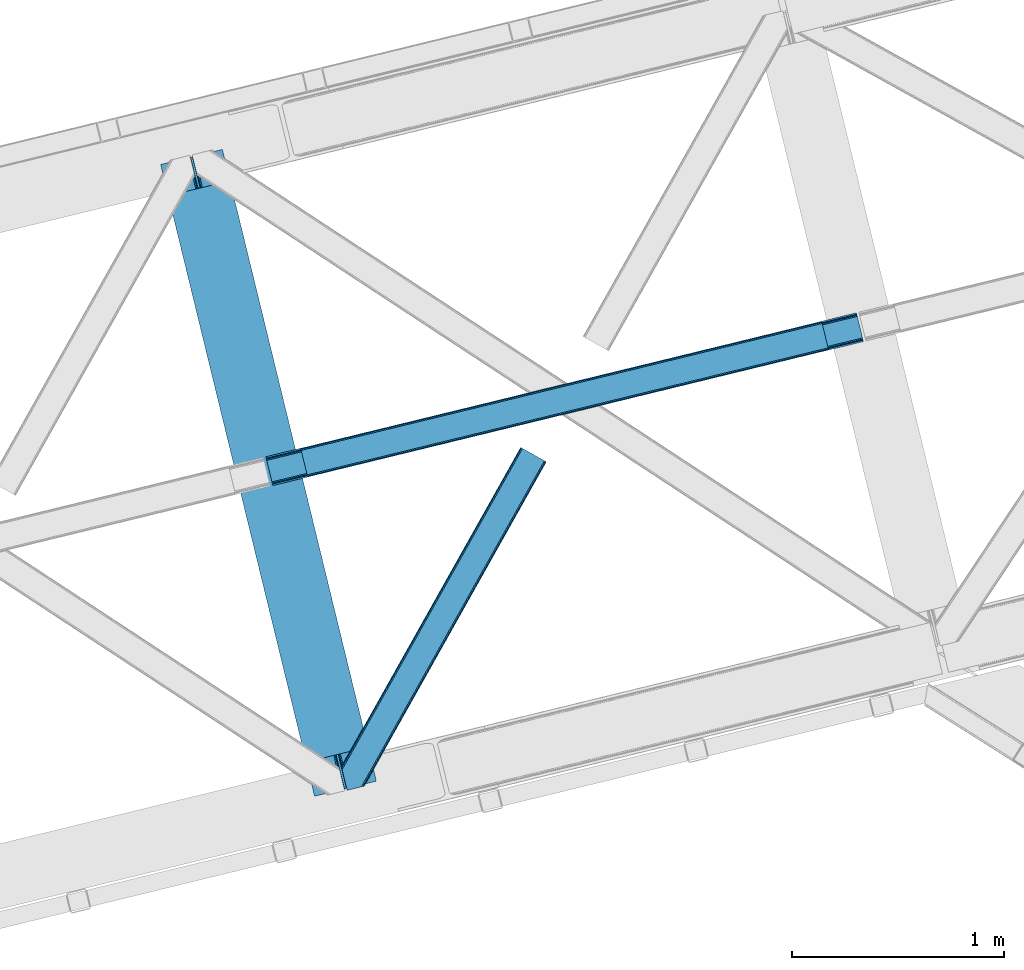
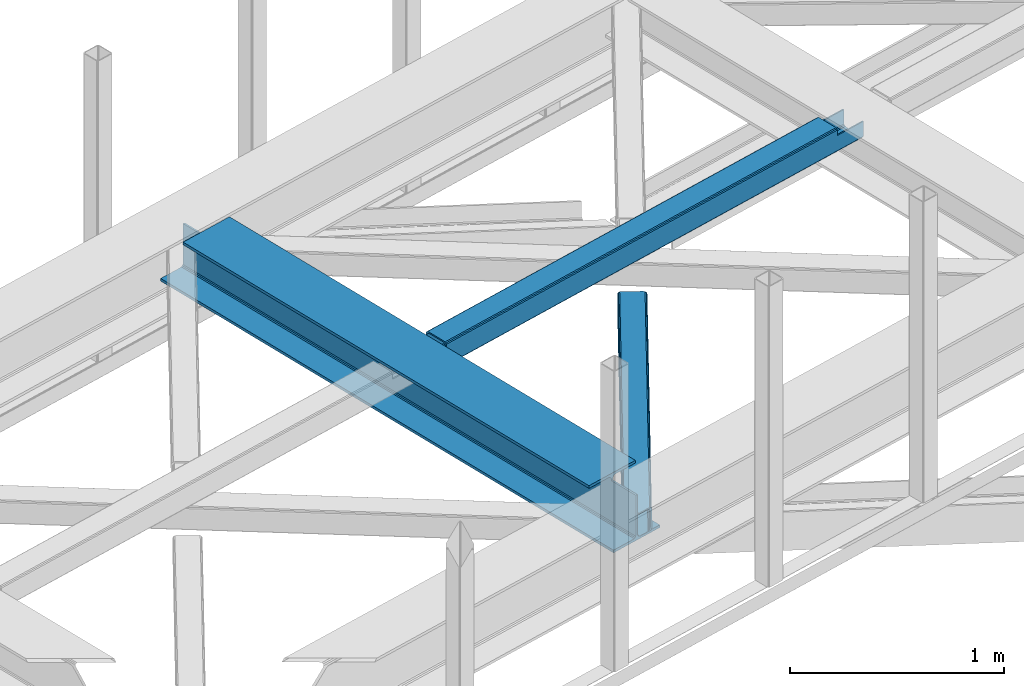
# One storey, part 55 of 67: 2 beams, 1 member.
"""IFC4 building model written with IfcOpenShell, lengths in millimetres."""

from ifc_helpers import new_model, entity, si_unit, converted_unit, derived_unit, direction, frame, origin, place, context, subcontext, project, spatial, triangles, polygons, material, type_object, element, save


model = new_model("IFC4")

# Units and contexts
model_context = context("Model", 3, precision=0.01, world=origin(), true_north=direction((6.12303176911189e-17, 1.0)))
plan_context = context("Plan", 3, precision=0.01, world=origin(), true_north=direction((6.12303176911189e-17, 1.0)))
body_context = subcontext(model_context, "Body", "Model", "MODEL_VIEW")
ifc_project = project(units=[si_unit("LENGTHUNIT", "METRE", prefix="MILLI"), si_unit("AREAUNIT", "SQUARE_METRE"), si_unit("VOLUMEUNIT", "CUBIC_METRE"), converted_unit("PLANEANGLEUNIT", "DEGREE", entity("IfcRatioMeasure", 0.0174532925199433), si_unit("PLANEANGLEUNIT", "RADIAN"), dimensions=[0, 0, 0, 0, 0, 0, 0]), si_unit("MASSUNIT", "GRAM", prefix="KILO"), derived_unit("MASSDENSITYUNIT", [(si_unit("MASSUNIT", "GRAM", prefix="KILO"), 1), (si_unit("LENGTHUNIT", "METRE"), -3)]), derived_unit("MOMENTOFINERTIAUNIT", [(si_unit("LENGTHUNIT", "METRE"), 4)]), si_unit("TIMEUNIT", "SECOND"), si_unit("FREQUENCYUNIT", "HERTZ"), si_unit("THERMODYNAMICTEMPERATUREUNIT", "DEGREE_CELSIUS"), derived_unit("THERMALTRANSMITTANCEUNIT", [(si_unit("MASSUNIT", "GRAM", prefix="KILO"), 1), (si_unit("THERMODYNAMICTEMPERATUREUNIT", "KELVIN"), -1), (si_unit("TIMEUNIT", "SECOND"), -3)]), derived_unit("VOLUMETRICFLOWRATEUNIT", [(si_unit("LENGTHUNIT", "METRE"), 3), (si_unit("TIMEUNIT", "SECOND"), -1)]), derived_unit("MASSFLOWRATEUNIT", [(si_unit("MASSUNIT", "GRAM", prefix="KILO"), 1), (si_unit("TIMEUNIT", "SECOND"), -1)]), derived_unit("ROTATIONALFREQUENCYUNIT", [(si_unit("TIMEUNIT", "SECOND"), -1)]), si_unit("ELECTRICCURRENTUNIT", "AMPERE"), si_unit("ELECTRICVOLTAGEUNIT", "VOLT"), si_unit("POWERUNIT", "WATT"), si_unit("FORCEUNIT", "NEWTON", prefix="KILO"), si_unit("ILLUMINANCEUNIT", "LUX"), si_unit("LUMINOUSFLUXUNIT", "LUMEN"), si_unit("LUMINOUSINTENSITYUNIT", "CANDELA"), derived_unit("USERDEFINED", [(si_unit("MASSUNIT", "GRAM", prefix="KILO"), -1), (si_unit("LENGTHUNIT", "METRE"), -2), (si_unit("TIMEUNIT", "SECOND"), 3), (si_unit("LUMINOUSFLUXUNIT", "LUMEN"), 1)]), derived_unit("LINEARVELOCITYUNIT", [(si_unit("LENGTHUNIT", "METRE"), 1), (si_unit("TIMEUNIT", "SECOND"), -1)]), si_unit("PRESSUREUNIT", "PASCAL"), derived_unit("USERDEFINED", [(si_unit("LENGTHUNIT", "METRE"), -2), (si_unit("MASSUNIT", "GRAM", prefix="KILO"), 1), (si_unit("TIMEUNIT", "SECOND"), -2)]), derived_unit("LINEARFORCEUNIT", [(si_unit("MASSUNIT", "GRAM", prefix="KILO"), 1), (si_unit("LENGTHUNIT", "METRE"), 1), (si_unit("TIMEUNIT", "SECOND"), -2), (si_unit("LENGTHUNIT", "METRE"), -1)]), derived_unit("PLANARFORCEUNIT", [(si_unit("MASSUNIT", "GRAM", prefix="KILO"), 1), (si_unit("LENGTHUNIT", "METRE"), 1), (si_unit("TIMEUNIT", "SECOND"), -2), (si_unit("LENGTHUNIT", "METRE"), -2)])], contexts=[model_context, plan_context])

# Site, building, storey
site_placement = place(None, origin())
site = spatial("IfcSite", under=ifc_project, at=site_placement, CompositionType="ELEMENT")
building_placement = place(site_placement, origin())
building = spatial("IfcBuilding", under=site, at=building_placement, CompositionType="ELEMENT")
storey_placement = place(building_placement, frame((0.0, 0.0, 19800.0)))
storey = spatial("IfcBuildingStorey", under=building, at=storey_placement, CompositionType="ELEMENT", Elevation=19800.0)

# Beams
ifc_material = material(Name="Metal painted (White)")
beam_type = type_object("IfcBeamType", PredefinedType="BEAM")
beam_1_placement = place(storey_placement, frame((-9086.33270000327, 15580.0394855194, 3807.02022389142)))
element("IfcBeam", 1, at=beam_1_placement, inside=storey, type_object=beam_type, material=ifc_material, ObjectType="Steel Beam", PredefinedType="BEAM", context=body_context, shape_type="Tessellation", body=[
    polygons([(1018.1664837833, 71.0478278971021, 15.5000000000008), (1018.1664837833, 71.0478278971021, 0.0), (291.465617442452, 3052.25531830421, 0.0), (291.465617442452, 3052.25531830421, 15.5000000000008), (894.779372399334, 40.9709140873313, 15.5000000000008), (168.078506058486, 3022.17840449444, 15.5000000000008), (888.087028625383, 39.3395844888265, 16.8701684147984), (161.386162284532, 3020.54707489594, 16.8701684147984), (882.413533524763, 37.956610033654, 20.7720779386478), (155.712667183913, 3019.16410044077, 20.7720779386478), (878.622625296189, 37.0325360459184, 26.6116982174294), (151.921758955338, 3018.24002645303, 26.6116982174294), (877.291435352789, 36.7080444135029, 33.500000000001), (150.590569011938, 3017.91553482062, 33.500000000001), (140.875048430526, 3015.54727389071, 33.500000000001), (140.875048430525, 3015.54727389071, 259.000000000002), (150.590569011936, 3017.91553482062, 259.000000000002), (0.0, 2981.20749040711, 0.0), (3.24860138789518e-12, 2981.20749040711, 15.4999999999965), (123.387111383965, 3011.28440421689, 15.5000000000008), (130.079455157938, 3012.91573381539, 16.8701684147984), (135.752950258554, 3014.29870827056, 20.7720779386391), (139.543858487129, 3015.2227822583, 26.6116982174294), (877.291435352786, 36.7080444135029, 259.000000000002), (867.575914771374, 34.3397834836014, 259.000000000002), (867.575914771377, 34.3397834836014, 33.500000000001), (866.24472482798, 34.0152918511859, 26.6116982174294), (862.453816599403, 33.0912178634502, 20.7720779386391), (856.780321498787, 31.70824340828, 16.8701684147984), (850.087977724816, 30.0769138097708, 15.5000000000008), (726.700866340855, 0.0, 15.4999999999965), (726.700866340851, 0.0, 0.0), (838.124523615913, 197.385937999181, 259.069791973884), (186.469722099971, 2870.72539801219, 259.000000000002), (186.693115201823, 2869.80895360721, 259.617303331124), (186.70550404545, 2869.75812937344, 266.500003008253), (837.979344808147, 197.981416001704, 266.500002998871), (837.979694928899, 197.979979696973, 260.000004007589), (828.499586345882, 194.645865944434, 259.006343171919), (828.27621632612, 195.562317481914, 259.617303331124), (828.263827482491, 195.613141715687, 266.500003008253), (176.989986719794, 2867.38985508742, 266.500002998871), (176.989636599042, 2867.39129139215, 260.000004007589), (176.844830940702, 2867.98534020594, 259.07612046749), (176.75420151856, 2868.35713708228, 259.000000000002), (839.310832678078, 198.30468544639, 273.388305639783), (843.101109266769, 199.231350618303, 279.227924098777), (848.774180214308, 200.616065081981, 283.129832400619), (855.466371895439, 202.248018612794, 284.500000377228), (978.853400583268, 232.325271667905, 284.500000138971), (978.851730776625, 232.332121736637, 299.999995328161), (687.386308679347, 161.283492472596, 299.999995890962), (687.387978486002, 161.276642403863, 284.500000701776), (810.775007173842, 191.353895458974, 284.500000463519), (817.467494070002, 192.984637925557, 283.129832461069), (823.141405718754, 194.365903570079, 279.227924137322), (826.93294050575, 195.287407219375, 273.388305663684), (175.658498849867, 2867.06658564273, 273.388305639783), (171.868222261169, 2866.13992047082, 279.227924098781), (166.195151313643, 2864.75520600715, 283.129832400619), (159.502959632494, 2863.12325247633, 284.500000377228), (36.1159309446587, 2833.04599942122, 284.500000138971), (36.117600751305, 2833.03914935249, 299.999995328161), (327.583022848581, 2904.08777861653, 299.999995890962), (327.581353041927, 2904.09462868526, 284.500000701776), (204.194324354092, 2874.01737563015, 284.500000463519), (197.50183745795, 2872.38663316357, 283.129832461069), (191.827925809185, 2871.00536751905, 279.227924137318), (188.036391022194, 2870.08386386975, 273.388305663684)], [[[1, 2, 3, 4]], [[5, 1, 4, 6]], [[7, 5, 6, 8]], [[9, 7, 8, 10]], [[11, 9, 10, 12]], [[13, 11, 12, 14]], [[15, 16, 17, 14, 12, 10, 8, 6, 4, 3, 18, 19, 20, 21, 22, 23]], [[13, 24, 25, 26, 27, 28, 29, 30, 31, 32, 2, 1, 5, 7, 9, 11]], [[2, 32, 18, 3]], [[32, 31, 19, 18]], [[31, 30, 20, 19]], [[27, 26, 15, 23]], [[28, 27, 23, 22]], [[29, 28, 22, 21]], [[30, 29, 21, 20]], [[33, 24, 13, 14, 17, 34, 35, 36, 37, 38]], [[25, 39, 40, 41, 42, 43, 44, 16, 15, 26]], [[39, 25, 24, 33]], [[45, 34, 17, 16]], [[41, 40, 38, 37, 46, 47, 48, 49, 50, 51, 52, 53, 54, 55, 56, 57]], [[42, 58, 59, 60, 61, 62, 63, 64, 65, 66, 67, 68, 69, 36, 35, 43]], [[46, 37, 36, 69]], [[47, 46, 69, 68]], [[48, 47, 68, 67]], [[49, 48, 67, 66]], [[50, 49, 66, 65]], [[51, 50, 65, 64]], [[52, 51, 64, 63]], [[53, 52, 63, 62]], [[54, 53, 62, 61]], [[55, 54, 61, 60]], [[56, 55, 60, 59]], [[57, 56, 59, 58]], [[41, 57, 58, 42]]], closed=False),
])
beam_2_placement = place(storey_placement, frame((-8589.59654839977, 17046.137433552, 3967.02022389142)))
element("IfcBeam", 2, at=beam_2_placement, inside=storey, type_object=beam_type, material=ifc_material, ObjectType="Steel Beam", PredefinedType="BEAM", context=body_context, shape_type="Tessellation", body=[
    polygons([(31.182392391782, 8.09507685196974, 17.8030399336114), (31.4978703677338, 6.80086440699434, 24.4999999999988), (2817.90917311747, 686.01809910328, 24.4999999999988), (2817.59369514152, 687.312311548251, 17.8030399336114), (30.2839871259284, 11.7806820741929, 12.1256313292298), (2816.69528987567, 690.997916770481, 12.1256313292298), (28.9394286278462, 17.2965800886818, 8.33210818105214), (2815.35073137759, 696.513814784967, 8.33210818105214), (27.35341374041, 23.8030254244748, 7.00000000000274), (2813.76471649015, 703.02026012076, 7.00000000000274), (4.21622439085534, 118.720708051138, 8.33210818105214), (5.80223927828939, 112.214262715347, 7.00000000000274), (2792.21354202803, 791.431497411635, 7.00000000000274), (2790.6275271406, 797.937942747428, 8.33210818105214), (2.87166589277206, 124.236606065627, 12.1256313292342), (2789.28296864251, 803.453840761912, 12.1256313292342), (1.97326062691843, 127.922211287854, 17.8030399336114), (2788.38456337666, 807.13944598414, 17.8030399336114), (1.65778265095143, 129.216423732823, 24.4999999999988), (2788.06908540069, 808.433658429109, 24.4999999999988), (33.1556530186549, 2.16573425859679e-12, 17.5000000000004), (33.1556530186528, 2.16573425859679e-12, 99.499999999999), (31.4978703677219, 6.80086440699217, 99.499999999999), (1.6577826509406, 129.216423732817, 99.499999999999), (6.49720277579036e-12, 136.017288139809, 99.499999999999), (9.74580416368554e-12, 136.017288139809, 17.5000000000004), (0.315477975968082, 134.72307569484, 10.803039933613), (1.21388324182172, 131.037470472617, 5.12563132923143), (2.55844173990608, 125.521572458128, 1.33210818105373), (4.14445662734013, 119.015127122333, 0.0), (29.0111963913267, 17.0021610174783, 0.0), (30.5972112787619, 10.4957156816875, 1.33210818105373), (31.9417697768441, 4.97981766719851, 5.12563132923576), (32.8401750426977, 1.29421244497107, 10.803039933613), (2786.41130274974, 815.234522836097, 17.5000000000004), (2786.41130274974, 815.234522836094, 99.499999999999), (2788.06908540067, 808.433658429104, 99.499999999999), (2817.90917311745, 686.018099103278, 99.499999999999), (2819.56695576838, 679.217234696288, 99.499999999999), (2819.56695576839, 679.217234696292, 17.5000000000004), (2819.25147779243, 680.511447141259, 10.803039933613), (2818.35307252658, 684.197052363484, 5.12563132923576), (2817.0085140285, 689.712950377975, 1.33210818105373), (2815.42249914106, 696.219395713764, 0.0), (2790.55575937708, 798.23236181862, 0.0), (2788.96974448964, 804.738807154411, 1.33210818105373), (2787.62518599156, 810.2547051689, 5.12563132923143), (2786.72678072571, 813.94031039113, 10.803039933613), (2653.72536552982, 645.996559503596, 115.5000123926), (2653.78173361469, 646.01029872221, 100.117303289864), (2654.6884273497, 646.231315480905, 99.499999999999), (194.718606580807, 46.58768115868, 99.5063429816656), (195.631369831918, 46.8101414945073, 100.117301735448), (195.690168193629, 46.8244741223611, 115.5), (2656.34621000063, 639.430451073913, 99.499999999999), (2655.43964990838, 639.209466900405, 100.117303484932), (2655.38006714071, 639.194943868063, 122.500007895425), (197.345360928044, 40.0229783796067, 122.500002534479), (197.338587096737, 40.0213271441522, 100.500009163303), (196.748205195732, 39.8773799905108, 99.5697919021647), (2624.8483491876, 768.646841677423, 99.5063429816656), (2623.93924032813, 768.425271514709, 100.117299778624), (2623.88287224327, 768.411532296091, 115.50000888136), (165.850080476843, 169.240033448186, 115.5), (165.840462203339, 169.237688832046, 100.50000941238), (165.250325295041, 169.093836777338, 99.5761204674868), (2622.81875057268, 775.357142845592, 99.5697919021647), (163.22074576778, 175.804071762186, 99.499999999999), (164.133244938518, 176.026503182401, 100.117301984524), (164.189439987629, 176.04020120897, 122.500002796667), (2622.22174126677, 775.211580304176, 122.500003994045), (2622.23184455559, 775.21404371874, 100.500018741102), (2622.53385542114, 773.916547682008, 129.196959150505), (2623.42719094673, 770.229706340318, 134.874360354937), (2624.7684819508, 764.713011635509, 138.667878733795), (2626.35352903681, 758.206330327434, 139.999985502214), (2651.22427808373, 656.194341778123, 139.999991354279), (2652.81177220132, 649.688257112721, 138.667885332354), (2654.16003176176, 644.173261502491, 134.874367586349), (2655.06379646897, 640.488963035541, 129.196966804773), (2653.41217589812, 647.291329899609, 122.196975799125), (2652.50841119091, 650.975628366566, 127.874376580702), (2651.16015163047, 656.490623976793, 131.667894326702), (2649.57265751289, 662.996708642196, 133.000000348631), (2628.01800833888, 751.407098718266, 132.999995276841), (2626.43296125288, 757.913780026341, 131.667888508414), (2625.09167024881, 763.430474731148, 127.874370129564), (2624.19833472322, 767.11731607284, 122.196968925133), (164.878528418714, 169.003207355196, 99.499999999999), (193.131726453735, 57.3201898040421, 131.667891818946), (191.5457115663, 63.826635139835, 133.0), (194.476284951818, 51.8042917895531, 127.874368670764), (195.374690217671, 48.11868656733, 122.196960066391), (169.994537104179, 152.237872430709, 133.0), (166.165558452806, 167.945821003219, 122.196960066391), (167.063963718659, 164.260215780991, 127.874368670764), (168.408522216743, 158.744317766505, 131.667891818946), (197.031411944066, 41.3175635421159, 129.196961104604), (196.136488323058, 45.0040174739003, 134.874366301861), (194.794244157307, 50.5204796458751, 138.667887185257), (193.209023953575, 57.0271186992015, 139.999994588639), (168.341882306934, 159.03998683839, 139.999994981919), (166.755021471182, 165.546225960036, 138.667887628704), (165.408105180725, 171.06154922293, 134.874366787843), (164.506189230959, 174.746298656826, 129.196961619)], [[[1, 2, 3, 4]], [[5, 1, 4, 6]], [[7, 5, 6, 8]], [[9, 7, 8, 10]], [[11, 12, 13, 14]], [[15, 11, 14, 16]], [[17, 15, 16, 18]], [[19, 17, 18, 20]], [[12, 9, 10, 13]], [[21, 22, 23, 2, 1, 5, 7, 9, 12, 11, 15, 17, 19, 24, 25, 26, 27, 28, 29, 30, 31, 32, 33, 34]], [[35, 36, 37, 20, 18, 16, 14, 13, 10, 8, 6, 4, 3, 38, 39, 40, 41, 42, 43, 44, 45, 46, 47, 48]], [[49, 50, 51, 38, 3, 2, 23, 52, 53, 54]], [[55, 39, 38, 51]], [[39, 55, 56, 57, 58, 59, 60, 22, 21, 40]], [[32, 31, 44, 43]], [[33, 32, 43, 42]], [[34, 33, 42, 41]], [[21, 34, 41, 40]], [[31, 30, 45, 44]], [[27, 26, 35, 48]], [[28, 27, 48, 47]], [[29, 28, 47, 46]], [[30, 29, 46, 45]], [[20, 37, 61, 62, 63, 64, 65, 66, 24, 19]], [[67, 36, 35, 26, 25, 68, 69, 70, 71, 72]], [[36, 67, 61, 37]], [[72, 71, 73, 74, 75, 76, 77, 78, 79, 80, 57, 56, 50, 49, 81, 82, 83, 84, 85, 86, 87, 88, 63, 62]], [[60, 52, 23, 22]], [[25, 24, 89, 68]], [[90, 91, 84, 83]], [[92, 90, 83, 82]], [[93, 92, 82, 81]], [[54, 93, 81, 49]], [[94, 85, 84, 91]], [[95, 64, 63, 88]], [[96, 95, 88, 87]], [[97, 96, 87, 86]], [[94, 97, 86, 85]], [[65, 64, 95, 96, 97, 94, 91, 90, 92, 93, 54, 53, 59, 58, 98, 99, 100, 101, 102, 103, 104, 105, 70, 69]], [[98, 58, 57, 80]], [[99, 98, 80, 79]], [[100, 99, 79, 78]], [[101, 100, 78, 77]], [[77, 76, 102, 101]], [[103, 102, 76, 75]], [[104, 103, 75, 74]], [[105, 104, 74, 73]], [[70, 105, 73, 71]]], closed=False),
])

# Member
member_type = type_object("IfcMemberType", PredefinedType="BRACE")
member_placement = place(storey_placement, frame((-8233.36081695557, 15608.2403137207, 3822.99993896484)))
element("IfcMember", 3, at=member_placement, inside=storey, type_object=member_type, ObjectType="Steel Horizontal Brace", PredefinedType="BRACE", context=body_context, shape_type="Tessellation", body=[
    triangles([(967.681050109863, 1549.66471252441, 122.499499511719), (966.521237182617, 1550.31699829101, 129.196765136719), (108.493377685547, 19.761584472657, 122.499499511719), (106.721974182128, 19.3302154541016, 129.196765136719), (963.215043640136, 1552.17502441406, 134.87548828125), (101.679258728027, 18.1012207031254, 134.87548828125), (958.263020324707, 1554.95392456055, 138.668280029298), (94.1378585815428, 16.2629608154293, 138.668280029298), (952.422679138183, 1558.23395690918, 140.00075683594), (85.2360763549805, 14.0921630859375, 140.00075683594), (967.681050109863, 1549.66471252441, 17.5012573242202), (108.493377685547, 19.761584472657, 17.5012573242202), (6.07462921142542, 87.5702362060547, 140.00075683594), (27.4210006713856, 0.0, 140.00075683594), (860.874778747559, 1609.64826049805, 140.00075683594), (855.034437561035, 1612.92829284668, 138.668280029298), (3.74977111816406, 97.1068634033199, 138.668280029298), (850.082414245605, 1615.70719299316, 134.87548828125), (1.77896118164063, 105.192416381837, 134.87548828125), (846.776220703125, 1617.56521911621, 129.196765136719), (0.462181091308594, 110.594412231445, 129.196765136719), (845.616407775879, 1618.21750488281, 122.499499511719), (0.0, 112.491970825195, 122.499499511719), (845.616407775879, 1618.21750488281, 17.5012573242202), (0.0, 112.491970825195, 17.5012573242202), (966.521237182617, 1550.31699829101, 10.8039916992202), (106.721974182128, 19.3302154541016, 10.8039916992202), (156.767756652832, 115.413885498047, 5.52059326172093), (963.215043640136, 1552.17502441406, 5.12526855468968), (156.952047729492, 116.778918457032, 5.02062377929906), (102.189692687988, 18.2256317138672, 5.52059326172093), (958.263020324707, 1554.95392456055, 1.33247680664135), (157.131687927245, 118.142788696288, 4.52065429687718), (155.381794738769, 125.321420288086, 1.33247680664135), (952.422679138183, 1558.23395690918, 0.0), (153.056936645507, 134.858047485352, 0.0), (124.438916015624, 252.261346435547, 0.0), (94.4628387451166, 244.953652954102, 0.0), (860.874778747559, 1609.64826049805, 0.0), (77.5132919311518, 240.822509765625, 5.52059326172093), (85.5657073974608, 242.785180664063, 1.33247680664135), (123.842440795898, 252.116006469727, 5.44385375976708), (124.438916015624, 252.261346435547, 4.52065429687718), (846.776220703125, 1617.56521911621, 10.8039916992202), (1.68013000488281, 112.178036499023, 10.9621215820334), (0.251147460936409, 111.460638427734, 12.5201660156272), (850.082414245605, 1615.70719299316, 5.12526855468968), (855.034437561035, 1612.92829284668, 1.33247680664135), (6.66994171142505, 114.682534790039, 5.52059326172093), (34.2211669921871, 1.65687561035156, 5.52059326172093), (123.467463684082, 252.024151611327, 5.52059326172093), (32.7846267700188, 1.30689697265552, 6.99957275390625), (12.4672622680664, 84.6564605712883, 6.99957275390625), (9.18839263916016, 92.4908660888668, 8.3320495605476), (4.07649536132703, 95.7674102783203, 12.5201660156272), (75.9366439819332, 11.8260223388679, 6.99957275390625), (946.321307373047, 1561.66165466309, 6.99957275390625), (866.976150512695, 1606.22056274414, 6.99957275390625), (861.135809326172, 1609.49943237305, 8.3320495605476), (856.187855529784, 1612.28065795899, 12.1248413085959), (852.877592468261, 1614.1375213623, 17.8035644531265), (2.89226531982422, 100.625253295899, 17.8035644531265), (851.717779541015, 1614.78980712891, 24.5008300781265), (2.43008422851563, 102.522811889648, 24.5008300781265), (961.579678344727, 1553.09241027832, 24.5008300781265), (960.415214538574, 1553.7435333252, 17.8035644531265), (99.1892944335932, 17.4942810058601, 24.5008300781265), (97.4178909301754, 17.0617492675774, 17.8035644531265), (957.109602355957, 1555.60155944824, 12.1248413085959), (92.3798263549797, 15.8339172363285, 12.1248413085959), (952.16164855957, 1558.38278503418, 8.3320495605476), (84.8337753295891, 13.994494628907, 8.3320495605476), (961.579678344727, 1553.09241027832, 115.499926757813), (99.1892944335932, 17.4942810058601, 115.499926757813), (84.8337753295891, 13.994494628907, 131.668707275392), (75.9366439819332, 11.8260223388679, 133.001184082033), (27.4210006713856, 0.0, 133.001184082033), (92.3798263549797, 15.8339172363285, 127.873590087893), (97.4178909301754, 17.0617492675774, 122.197192382813), (946.321307373047, 1561.66165466309, 133.001184082033), (952.16164855957, 1558.38278503418, 131.668707275392), (957.109602355957, 1555.60155944824, 127.873590087893), (960.415214538574, 1553.7435333252, 122.197192382813), (856.187855529784, 1612.28065795899, 127.873590087893), (866.976150512695, 1606.22056274414, 133.001184082033), (861.135809326172, 1609.49943237305, 131.668707275392), (851.717779541015, 1614.78980712891, 115.499926757813), (852.877592468261, 1614.1375213623, 122.197192382813), (4.20904541015625, 95.2232574462887, 127.873590087893), (2.89226531982422, 100.625253295899, 122.197192382813), (6.17985534667969, 87.1377044677738, 131.668707275392), (8.50471343994104, 77.6010772705085, 133.001184082033), (2.43008422851563, 102.522811889648, 115.499926757813)], [[1, 2, 3], [4, 3, 2], [2, 5, 4], [6, 4, 5], [5, 7, 6], [8, 6, 7], [7, 9, 8], [10, 8, 9], [11, 1, 3], [3, 12, 11], [13, 10, 9], [10, 13, 14], [9, 15, 13], [15, 16, 17], [17, 13, 15], [16, 18, 19], [19, 17, 16], [18, 20, 21], [21, 19, 18], [20, 22, 23], [23, 21, 20], [22, 24, 25], [25, 23, 22], [26, 27, 28], [28, 29, 26], [28, 30, 29], [27, 31, 28], [30, 32, 29], [30, 33, 32], [33, 34, 32], [35, 32, 36], [34, 36, 32], [26, 11, 12], [12, 27, 26], [37, 38, 39], [36, 37, 35], [39, 35, 37], [38, 40, 41], [38, 37, 42], [38, 42, 40], [42, 37, 43], [43, 36, 33], [36, 43, 37], [34, 33, 36], [24, 44, 45], [45, 46, 24], [47, 48, 41], [45, 44, 40], [44, 47, 40], [40, 49, 45], [41, 40, 47], [48, 39, 38], [38, 41, 48], [46, 25, 24], [31, 49, 28], [31, 50, 49], [40, 28, 49], [51, 28, 40], [50, 52, 53], [49, 53, 54], [53, 49, 50], [55, 45, 49], [49, 54, 55], [46, 45, 55], [53, 56, 57], [56, 53, 52], [57, 58, 53], [59, 60, 55], [60, 61, 62], [62, 55, 60], [61, 63, 64], [64, 62, 61], [58, 59, 54], [54, 53, 58], [55, 54, 59], [65, 66, 67], [68, 67, 66], [66, 69, 68], [70, 68, 69], [69, 71, 70], [72, 70, 71], [71, 57, 72], [56, 72, 57], [73, 65, 67], [67, 74, 73], [8, 10, 75], [14, 76, 10], [76, 14, 77], [76, 75, 10], [78, 8, 75], [78, 6, 8], [6, 79, 4], [79, 6, 78], [3, 79, 74], [79, 3, 4], [56, 31, 72], [68, 70, 31], [70, 72, 31], [56, 50, 31], [50, 56, 52], [67, 68, 12], [27, 12, 68], [3, 67, 12], [67, 3, 74], [68, 31, 27], [80, 81, 75], [75, 76, 80], [81, 82, 78], [78, 75, 81], [82, 83, 79], [79, 78, 82], [83, 73, 74], [74, 79, 83], [26, 69, 66], [65, 1, 11], [26, 66, 11], [26, 29, 69], [66, 65, 11], [69, 29, 32], [57, 35, 39], [35, 71, 32], [71, 35, 57], [71, 69, 32], [2, 82, 5], [73, 1, 65], [1, 83, 2], [83, 1, 73], [2, 83, 82], [9, 80, 15], [7, 5, 82], [82, 81, 7], [81, 80, 9], [9, 7, 81], [60, 48, 47], [39, 58, 57], [39, 59, 58], [59, 39, 48], [60, 59, 48], [63, 24, 22], [44, 61, 60], [47, 44, 60], [61, 44, 24], [63, 61, 24], [16, 84, 18], [15, 80, 85], [85, 86, 15], [86, 84, 16], [16, 15, 86], [20, 18, 84], [22, 87, 63], [88, 22, 20], [22, 88, 87], [88, 20, 84], [89, 19, 90], [91, 92, 13], [92, 14, 13], [92, 77, 14], [17, 91, 13], [89, 17, 19], [89, 91, 17], [23, 64, 93], [21, 90, 19], [93, 90, 23], [90, 21, 23], [25, 64, 23], [46, 55, 62], [62, 64, 25], [25, 46, 62], [76, 92, 80], [76, 77, 92], [85, 80, 92], [63, 87, 93], [93, 64, 63], [87, 88, 93], [90, 93, 88], [88, 84, 90], [89, 90, 84], [84, 86, 89], [91, 89, 86], [86, 85, 91], [92, 91, 85]]),
])

save(model, "model.ifc")
